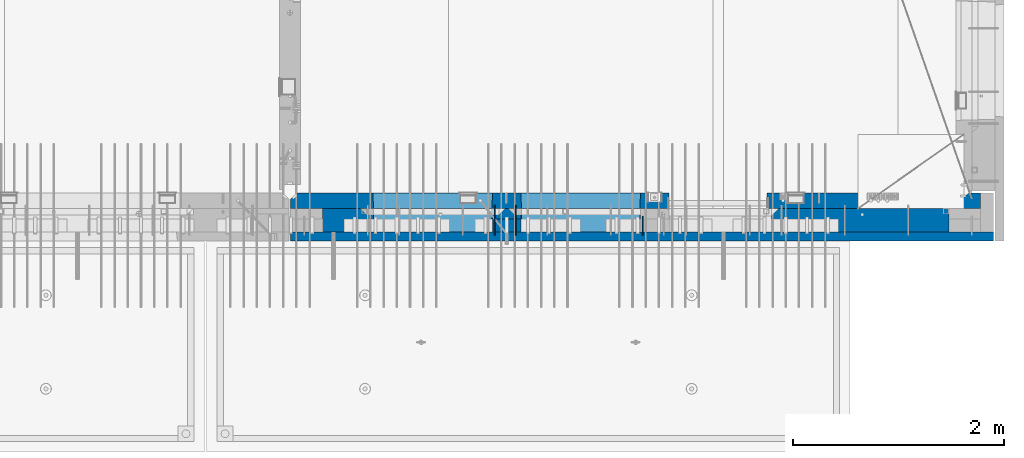
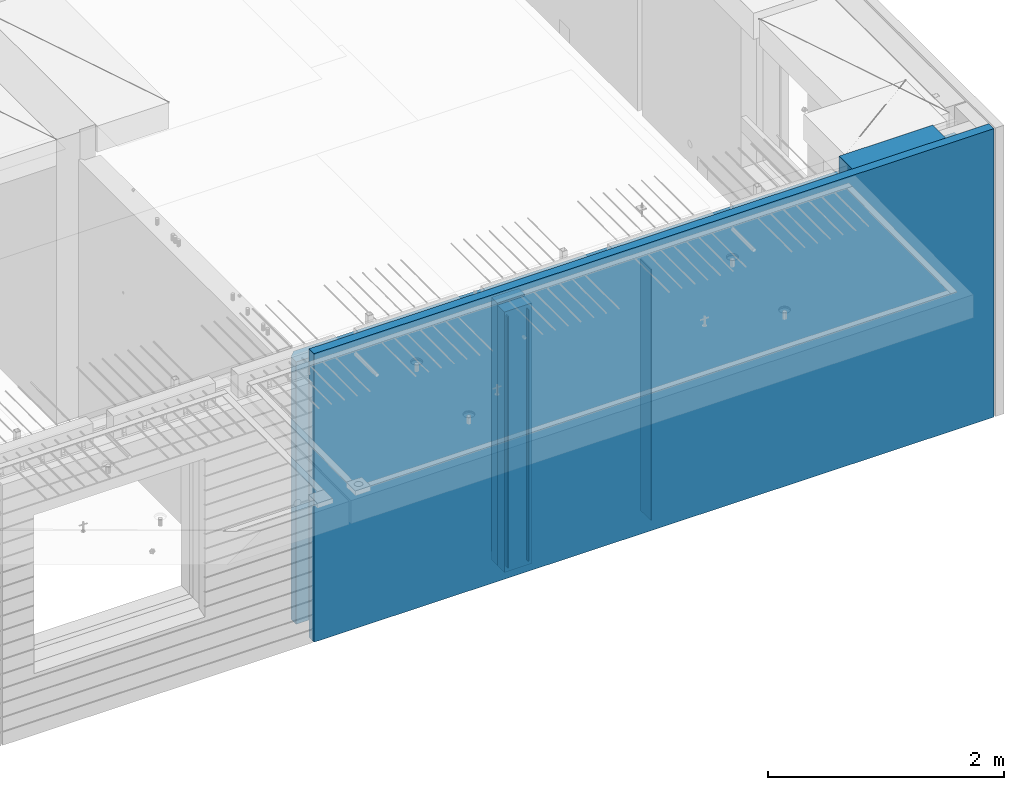
# One storey, part 233 of 349: 8 walls, 1 element without a shape of its own.
"""IFC2X3 building model written with IfcOpenShell, lengths in millimetres."""

from ifc_helpers import new_model, si_unit, frame, origin_with_axes, place, context, subcontext, project, spatial, faceted_brep, material, type_object, element, aggregate, save


model = new_model("IFC2X3")

# Units and contexts
model_context = context("Model", 3, precision=1e-05, world=origin_with_axes())
body_context = subcontext(model_context, "Body", "Model", "MODEL_VIEW")
ifc_project = project(units=[si_unit("LENGTHUNIT", "METRE", prefix="MILLI"), si_unit("AREAUNIT", "SQUARE_METRE"), si_unit("VOLUMEUNIT", "CUBIC_METRE"), si_unit("MASSUNIT", "GRAM", prefix="KILO"), si_unit("TIMEUNIT", "SECOND"), si_unit("PLANEANGLEUNIT", "RADIAN"), si_unit("SOLIDANGLEUNIT", "STERADIAN"), si_unit("THERMODYNAMICTEMPERATUREUNIT", "DEGREE_CELSIUS"), si_unit("LUMINOUSINTENSITYUNIT", "LUMEN")], contexts=[model_context])

# Site, building, storey
site_placement = place(None, origin_with_axes())
site = spatial("IfcSite", under=ifc_project, at=site_placement, CompositionType="ELEMENT")
building_placement = place(site_placement, origin_with_axes())
building = spatial("IfcBuilding", under=site, at=building_placement, CompositionType="ELEMENT")
storey_placement = place(building_placement, origin_with_axes())
storey = spatial("IfcBuildingStorey", under=building, at=storey_placement, Name="4", CompositionType="ELEMENT", Elevation=0.0)

# Assembly, walls
assembly_placement = place(storey_placement, origin_with_axes())
assembly = element("IfcElementAssembly", 1, at=assembly_placement, inside=storey, AssemblyPlace="NOTDEFINED", PredefinedType="REINFORCEMENT_UNIT")
ifc_material_1 = material(Name="Undefined")
wall_type_1 = type_object("IfcWallType", PredefinedType="NOTDEFINED")
wall_1_placement = place(assembly_placement, frame((31944.9998946285, 7780.0, 92115.0), z_axis=(0.0, 0.0, 1.0), x_axis=(0.0, -1.0, 0.0)))
wall_1 = element("IfcWall", 2, at=wall_1_placement, type_object=wall_type_1, material=ifc_material_1, Name="(PD)", context=body_context, shape_type="Brep", body=[
    faceted_brep([(0.0, 5.0, -1300.0), (0.0, 5.0, 1300.0), (180.0, 5.0, 1300.0), (180.0, 5.0, -1300.0), (0.0, -5.0, 1300.0), (180.0, -5.0, 1300.0), (0.0, -5.0, -1300.0), (180.0, -5.0, -1300.0)], [[[0, 1, 2, 3]], [[1, 4, 5, 2]], [[4, 6, 7, 5]], [[6, 0, 3, 7]], [[5, 7, 3, 2]], [[6, 4, 1, 0]]]),
])
wall_2_placement = place(assembly_placement, frame((30545.0021834468, 7880.0, 92115.0), z_axis=(0.0, 0.0, 1.0), x_axis=(0.0, -1.0, 0.0)))
wall_2 = element("IfcWall", 3, at=wall_2_placement, type_object=wall_type_1, material=ifc_material_1, Name="(PD)", context=body_context, shape_type="Brep", body=[
    faceted_brep([(0.0, 5.0, -1300.0), (0.0, 5.0, 1300.0), (280.0, 5.0, 1300.0), (280.0, 5.0, -1300.0), (0.0, -5.0, 1300.0), (280.0, -5.0, 1300.0), (0.0, -5.0, -1300.0), (280.0, -5.0, -1300.0)], [[[0, 1, 2, 3]], [[1, 4, 5, 2]], [[4, 6, 7, 5]], [[6, 0, 3, 7]], [[5, 7, 3, 2]], [[6, 4, 1, 0]]]),
])
wall_3_placement = place(assembly_placement, frame((30745.0021834468, 7880.0, 92115.0), z_axis=(0.0, 0.0, 1.0), x_axis=(0.0, -1.0, 0.0)))
wall_3 = element("IfcWall", 4, at=wall_3_placement, type_object=wall_type_1, material=ifc_material_1, Name="(PD)", context=body_context, shape_type="Brep", body=[
    faceted_brep([(0.0, 5.0, -1300.0), (0.0, 5.0, 1300.0), (280.0, 5.0, 1300.0), (280.0, 5.0, -1300.0), (0.0, -5.0, 1300.0), (280.0, -5.0, 1300.0), (0.0, -5.0, -1300.0), (280.0, -5.0, -1300.0)], [[[0, 1, 2, 3]], [[1, 4, 5, 2]], [[4, 6, 7, 5]], [[6, 0, 3, 7]], [[5, 7, 3, 2]], [[6, 4, 1, 0]]]),
])
ifc_material_2 = material(Name="COS5gt")
wall_type_2 = type_object("IfcWallType", PredefinedType="NOTDEFINED")
wall_4_placement = place(assembly_placement, frame((34845.0, 7740.0, 92247.5), z_axis=(0.0, 0.0, 1.0), x_axis=(-1.0, 3.00000001838171e-08, 0.0)))
wall_4 = element("IfcWall", 5, at=wall_4_placement, type_object=wall_type_2, material=ifc_material_2, context=body_context, shape_type="Brep", body=[
    faceted_brep([(917.0, -110.0, 1492.5), (917.0, -110.0, 1202.5), (917.0, 110.0, 1202.5), (917.0, 110.0, 1492.5), (0.0, 110.0, 1492.5), (0.0, -110.0, 1492.5), (0.0, -110.0, -1492.5), (1680.00110766775, -110.0, -1492.5), (1680.00110766775, -110.0, 857.5), (2649.99996185248, -110.0, 857.5), (2649.99996185248, -110.0, 1202.5), (0.0, 90.0, -1492.5), (1680.00110766775, 90.0, -1492.5), (0.0, 90.0, -1442.5), (1680.00110766775, 90.0, -1442.5), (0.0, 110.0, -1442.5), (1680.00110766775, 110.0, -1442.5), (1680.00110766775, 110.0, 857.5), (2649.99996185248, 110.0, 857.5), (2649.99996185248, -10.0, 857.5), (2649.99996185248, -10.0, 1202.5), (2649.99996185248, 110.0, 1202.5), (4049.99996185248, -10.0, 1202.5), (4049.99996185248, -10.0, -1492.5), (4049.99996185248, 90.0, -1492.5), (4049.99996185248, 90.0, -1442.5), (4049.99996185248, 110.0, -1442.5), (4049.99996185248, 110.0, 1202.5), (2920.0018706072, 110.0, 1202.5), (2920.0018706072, -10.0, 1202.5), (2920.0018706072, -110.0, 1202.5), (4049.99996185248, -110.0, 1202.5), (2920.0018706072, 110.0, -1442.5), (2920.0018706072, 90.0, -1442.5), (2920.0018706072, 90.0, -1492.5), (2920.0018706072, -10.0, -1492.5), (2920.0018706072, -110.0, -1492.5), (4045.94781655315, -110.0, -813.445945945947), (4040.0018706072, 110.0, -807.5), (4010.0018706072, 110.0, -807.5), (2960.0018706072, 110.0, -807.5), (2930.0018706072, 110.0, -807.5), (2924.05592466125, -110.0, -813.445945945947), (4049.99996185248, -110.0, -1492.5), (2924.05592466125, -110.0, 813.445945945947), (4045.94781655315, -110.0, 813.445945945947), (4040.0018706072, 110.0, -802.5), (4040.0018706072, 110.0, 807.5), (2930.0018706072, 110.0, 807.5), (2930.0018706072, 110.0, -802.5), (4320.0018706072, -10.0, 1202.5), (4320.0018706072, 110.0, 1202.5), (4320.0018706072, 110.0, -1442.5), (4320.0018706072, 90.0, -1442.5), (4320.0018706072, 90.0, -1492.5), (4320.0018706072, -10.0, -1492.5), (5928.5, 90.0, -1442.5), (5928.5, 90.0, -1492.5), (5928.5, 110.0, -1442.5), (5928.5, 110.0, -1492.5), (5930.0, -110.0, -1492.5), (5930.0, 110.0, -1492.5), (5930.0, 110.0, 1202.5), (5930.0, -110.0, 1202.5), (4320.0018706072, -110.0, -1492.5), (4320.0018706072, -110.0, 1202.5), (5445.94552773479, -110.0, -813.445945945947), (5439.99958178884, 110.0, -807.5), (5409.99958178884, 110.0, -807.5), (4359.99958178884, 110.0, -807.5), (4329.99958178884, 110.0, -807.5), (4324.05363584289, -110.0, -813.445945945947), (4324.05363584289, -110.0, 813.445945945947), (5445.94552773479, -110.0, 813.445945945947), (5439.99958178884, 110.0, -802.5), (5439.99958178884, 110.0, 807.5), (4329.99958178884, 110.0, 807.5), (4329.99958178884, 110.0, -802.5)], [[[0, 1, 2, 3]], [[4, 5, 0, 3]], [[1, 0, 5, 6, 7, 8, 9, 10]], [[6, 11, 12, 7]], [[11, 13, 14, 12]], [[11, 6, 5, 4, 15, 13]], [[13, 15, 16, 14]], [[7, 12, 14, 16, 17, 8]], [[8, 17, 18, 19, 9]], [[10, 9, 19, 20]], [[2, 1, 10, 20, 21]], [[17, 16, 15, 4, 3, 2, 21, 18]], [[20, 19, 18, 21]], [[22, 23, 24, 25, 26, 27]], [[28, 29, 30, 31, 22, 27]], [[29, 28, 32, 33, 34, 35]], [[30, 29, 35, 36]], [[37, 38, 39, 40, 41, 42]], [[43, 31, 30, 36], [37, 42, 44, 45]], [[46, 38, 37, 45, 47]], [[44, 48, 47, 45]], [[42, 41, 49, 48, 44]], [[32, 28, 27, 26], [41, 40, 39, 38, 46, 47, 48, 49]], [[33, 32, 26, 25]], [[34, 33, 25, 24]], [[34, 24, 23, 43, 36, 35]], [[31, 43, 23, 22]], [[50, 51, 52, 53, 54, 55]], [[56, 57, 54, 53]], [[58, 56, 53, 52]], [[57, 56, 58, 59]], [[60, 61, 62, 63]], [[54, 57, 59, 61, 60, 64, 55]], [[65, 50, 55, 64]], [[66, 67, 68, 69, 70, 71]], [[60, 63, 65, 64], [66, 71, 72, 73]], [[74, 67, 66, 73, 75]], [[72, 76, 75, 73]], [[71, 70, 77, 76, 72]], [[62, 61, 59, 58, 52, 51], [70, 69, 68, 67, 74, 75, 76, 77]], [[65, 63, 62, 51, 50]]]),
])
ifc_material_3 = material(Name="CONCRETE/C30/37")
wall_type_3 = type_object("IfcWallType", PredefinedType="NOTDEFINED")
wall_5_placement = place(assembly_placement, frame((35265.0, 7587.5, 92247.5), z_axis=(0.0, 0.0, 1.0), x_axis=(-1.0, 3.00000001838171e-08, 0.0)))
wall_5 = element("IfcWall", 6, at=wall_5_placement, type_object=wall_type_3, material=ifc_material_3, context=body_context, shape_type="Brep", body=[
    faceted_brep([(0.0, 42.5, -1492.5), (0.0, 42.5, 1492.5), (6650.0, 42.5, 1492.5), (6650.0, 42.5, -1492.5), (0.0, -42.5, 1492.5), (6650.0, -42.5, 1492.5), (0.0, -42.5, -1492.5), (6650.0, -42.5, -1492.5)], [[[0, 1, 2, 3]], [[1, 4, 5, 2]], [[4, 6, 7, 5]], [[6, 0, 3, 7]], [[5, 7, 3, 2]], [[6, 4, 1, 0]]]),
])
ifc_material_4 = material(Name="CONCRETE/C35/45")
wall_type_4 = type_object("IfcWallType", PredefinedType="NOTDEFINED")
wall_6_placement = place(assembly_placement, frame((35145.0, 7925.0, 92112.5), z_axis=(0.0, 0.0, 1.0), x_axis=(-1.0, 3.00000001838171e-08, 0.0)))
wall_6 = element("IfcWall", 7, at=wall_6_placement, type_object=wall_type_4, material=ifc_material_4, context=body_context, shape_type="Brep", body=[
    faceted_brep([(202.000000451517, -54.9999973486238, 1357.5), (202.000000451517, -54.9999973486238, -1357.5), (214.999999722531, -75.0, -1357.5), (214.999999722531, -75.0, 1357.5), (128.000000410604, -54.9999993903875, 1357.5), (128.000000410604, -54.9999993903875, -1357.5), (115.0, -75.0, 1357.5), (115.0, -75.0, -1357.5), (0.0, -75.0, -1357.5), (0.0, -75.0, 1357.5), (0.0, 75.0, 1357.5), (0.0, 75.0, -1357.5), (6470.0, -75.0, 1357.5), (6530.0, -15.0, 1357.5), (6530.0, 75.0, 1357.5), (6530.0, 75.0, -1357.5), (6530.0, -15.0, -1357.5), (6470.0, -75.0, -1357.5), (2950.00110766775, -75.0, -1357.5), (2946.15495382159, 75.0, -1357.5), (2950.00110766775, -75.0, 952.5), (2946.1549538216, 75.0, 948.653846153844), (2020.00110766775, -75.0, 952.5), (2023.8472615139, 75.0, 948.653846153844), (2020.00110766775, -75.0, -1357.5), (2023.8472615139, 75.0, -1357.5), (5749.99958178884, -75.0, -682.5), (5745.94552773479, 75.0, -678.445945945947), (4624.05363584289, 75.0, -678.445945945947), (4619.99958178884, -75.0, -682.5), (5749.99958178884, -75.0, 952.5), (5745.94552773479, 75.0, 948.445945945947), (4619.99958178884, -75.0, 952.5), (4624.05363584289, 75.0, 948.445945945947), (4345.94781655315, 75.0, -678.445945945947), (4345.94781655315, 75.0, 948.445945945947), (3224.05592466125, 75.0, 948.445945945947), (3224.05592466125, 75.0, -678.445945945947), (3220.0018706072, -75.0, -682.5), (3220.0018706072, -75.0, 952.5), (4350.0018706072, -75.0, -682.5), (4350.0018706072, -75.0, 952.5)], [[[0, 1, 2, 3]], [[4, 5, 1, 0]], [[6, 7, 5, 4]], [[8, 9, 10, 11]], [[0, 3, 12, 13, 14, 10, 9, 6, 4]], [[15, 14, 13, 16]], [[12, 17, 16, 13]], [[15, 16, 17, 18, 19]], [[19, 18, 20, 21]], [[22, 23, 21, 20]], [[24, 25, 23, 22]], [[26, 27, 28, 29]], [[27, 26, 30, 31]], [[32, 33, 31, 30]], [[29, 28, 33, 32]], [[11, 10, 14, 15, 19, 21, 23, 25], [34, 35, 36, 37], [27, 31, 33, 28]], [[38, 37, 36, 39]], [[40, 34, 37, 38]], [[34, 40, 41, 35]], [[39, 36, 35, 41]], [[24, 22, 20, 18, 17, 12, 3, 2], [40, 38, 39, 41], [26, 29, 32, 30]], [[8, 11, 25, 24, 2, 1, 5, 7]], [[9, 8, 7, 6]]]),
])
wall_type_5 = type_object("IfcWallType", PredefinedType="NOTDEFINED")
wall_7_placement = place(assembly_placement, frame((30795.0000381475, 7800.0, 92112.5), z_axis=(0.0, 0.0, 1.0), x_axis=(-1.0, 3.00000001838171e-08, 0.0)))
wall_7 = element("IfcWall", 8, at=wall_7_placement, type_object=wall_type_5, material=ifc_material_4, context=body_context, shape_type="Brep", body=[
    faceted_brep([(0.0, 50.0, -1357.5), (0.0, 50.0, 1357.5), (270.001908754726, 50.0, 1357.5), (270.001908754726, 50.0, -1357.5), (0.0, -50.0, 1357.5), (270.001908754726, -50.0, 1357.5), (0.0, -50.0, -1357.5), (270.001908754726, -50.0, -1357.5)], [[[0, 1, 2, 3]], [[1, 4, 5, 2]], [[4, 6, 7, 5]], [[6, 0, 3, 7]], [[5, 7, 3, 2]], [[6, 4, 1, 0]]]),
])
ifc_material_5 = material(Name="SPU")
wall_type_6 = type_object("IfcWallType", PredefinedType="NOTDEFINED")
wall_8_placement = place(assembly_placement, frame((30795.0000381475, 7690.0, 92102.5), z_axis=(0.0, 0.0, 1.0), x_axis=(-1.0, 3.00000001838171e-08, 0.0)))
wall_8 = element("IfcWall", 9, at=wall_8_placement, type_object=wall_type_6, material=ifc_material_5, context=body_context, shape_type="Brep", body=[
    faceted_brep([(0.0, 60.0, -1347.5), (0.0, 60.0, 1347.5), (270.001908754726, 60.0, 1347.5), (270.001908754726, 60.0, -1347.5), (0.0, -60.0, 1347.5), (270.001908754726, -60.0, 1347.5), (0.0, -60.0, -1347.5), (270.001908754726, -60.0, -1347.5)], [[[0, 1, 2, 3]], [[1, 4, 5, 2]], [[4, 6, 7, 5]], [[6, 0, 3, 7]], [[5, 7, 3, 2]], [[6, 4, 1, 0]]]),
])
aggregate(assembly, [wall_8, wall_7, wall_1, wall_2, wall_3, wall_4, wall_5, wall_6])

save(model, "model.ifc")
